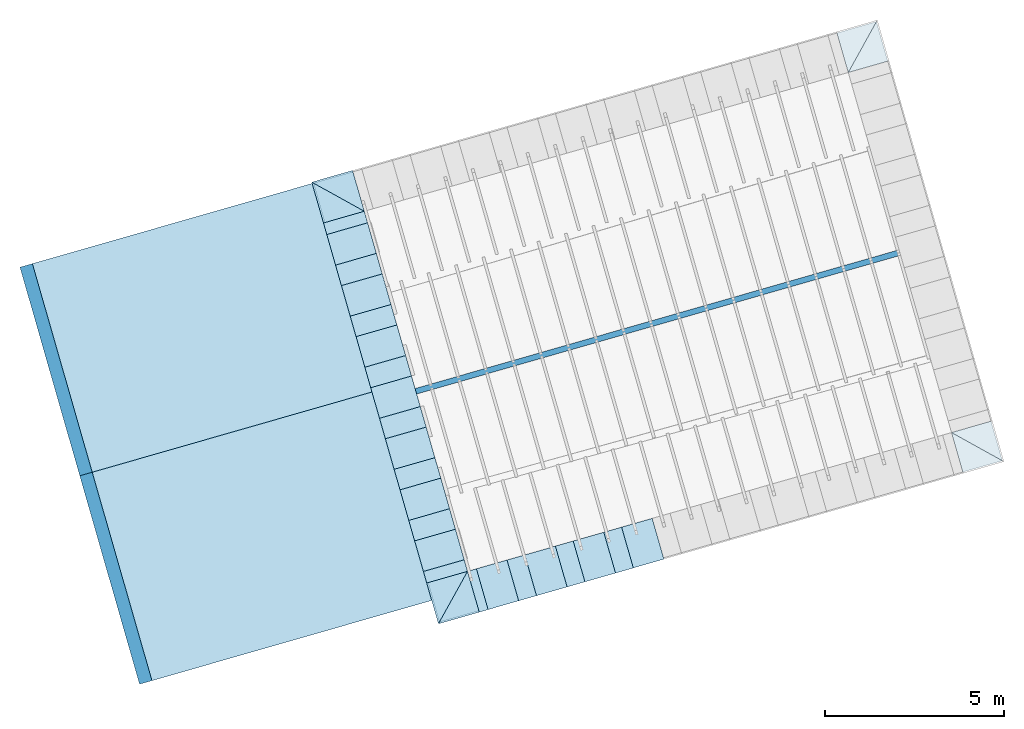
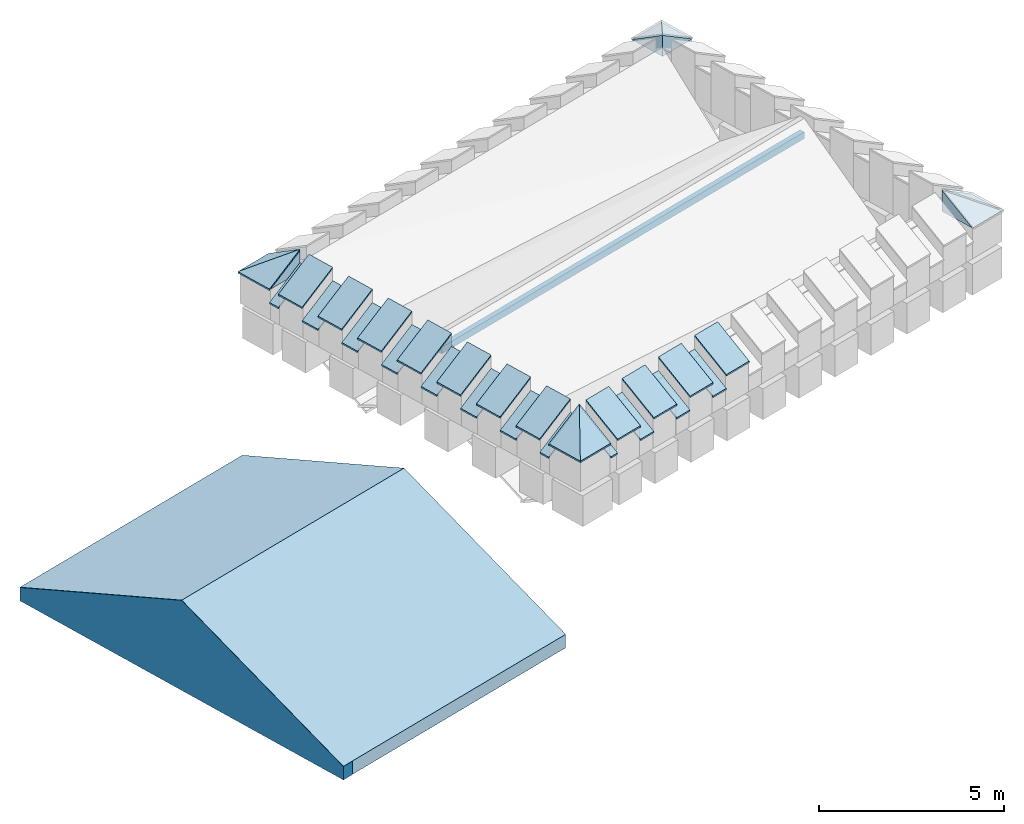
# One storey, part 1 of 10: 27 roofs, 6 slabs, 1 beam.
"""IFC4 building model written with IfcOpenShell, lengths in metres."""

from ifc_helpers import new_model, entity, si_unit, converted_unit, derived_unit, direction, frame, origin_with_axes, place, context, subcontext, project, spatial, polygons, source, transform, mapped, material, type_object, element, save


model = new_model("IFC4")

# Units and contexts
model_context = context("Model", 3, precision=1e-05, world=origin_with_axes(), true_north=direction((0.0, 1.0)))
body_context = subcontext(model_context, "Body", "Model", "MODEL_VIEW")
ifc_project = project(units=[si_unit("LENGTHUNIT", "METRE"), si_unit("AREAUNIT", "SQUARE_METRE"), si_unit("VOLUMEUNIT", "CUBIC_METRE"), converted_unit("PLANEANGLEUNIT", "DEGREE", entity("IfcPlaneAngleMeasure", 0.0174532925199433), si_unit("PLANEANGLEUNIT", "RADIAN"), dimensions=[0, 0, 0, 0, 0, 0, 0]), converted_unit("TIMEUNIT", "Year", entity("IfcTimeMeasure", 31557600.0), si_unit("TIMEUNIT", "SECOND"), dimensions=[0, 0, 1, 0, 0, 0, 0]), si_unit("MASSUNIT", "GRAM", prefix="KILO"), si_unit("THERMODYNAMICTEMPERATUREUNIT", "DEGREE_CELSIUS"), si_unit("LUMINOUSINTENSITYUNIT", "LUMEN"), si_unit("ENERGYUNIT", "JOULE", prefix="MEGA"), derived_unit("THERMALCONDUCTANCEUNIT", [(si_unit("POWERUNIT", "WATT"), 1), (si_unit("LENGTHUNIT", "METRE"), -1), (si_unit("THERMODYNAMICTEMPERATUREUNIT", "KELVIN"), -1)]), derived_unit("SPECIFICHEATCAPACITYUNIT", [(si_unit("ENERGYUNIT", "JOULE"), 1), (si_unit("MASSUNIT", "GRAM", prefix="KILO"), -1), (si_unit("THERMODYNAMICTEMPERATUREUNIT", "KELVIN"), -1)]), derived_unit("MASSDENSITYUNIT", [(si_unit("MASSUNIT", "GRAM", prefix="KILO"), 1), (si_unit("VOLUMEUNIT", "CUBIC_METRE"), -1)])], contexts=[model_context])

# Site, building, storey
site_placement = place(None, frame((0.0, 0.0, 0.0), z_axis=(0.0, 0.0, 1.0), x_axis=(0.9612616959383189, 0.2756373558169991, 0.0)))
site = spatial("IfcSite", under=ifc_project, at=site_placement, CompositionType="ELEMENT")
building_placement = place(site_placement, origin_with_axes())
building = spatial("IfcBuilding", under=site, at=building_placement, CompositionType="ELEMENT")
storey_placement = place(building_placement, frame((0.0, 0.0, 11.0), z_axis=(0.0, 0.0, 1.0), x_axis=(1.0, 0.0, 0.0)))
storey = spatial("IfcBuildingStorey", under=building, at=storey_placement, Name="Dach", CompositionType="ELEMENT", Elevation=11.0)

# Beam
ifc_material_1 = material()
beam_type = type_object("IfcBeamType", Name="160 x 220", PredefinedType="JOIST")
beam_placement = place(storey_placement, frame((15.96285962749732, 12.91602382317144, 1.313903544132387), z_axis=(0.0, 0.0, 1.0), x_axis=(0.0, -1.0, 0.0)))
element("IfcBeam", 1, at=beam_placement, inside=storey, type_object=beam_type, material=ifc_material_1, Name="007", PredefinedType="JOIST", context=body_context, shape_type="Tessellation", body=[
    polygons([(0.08000000000000007, 0.3999999994771404, 0.0), (0.0799999999999983, 14.48857175722328, 0.0), (-0.08000000000000007, 14.48857175722327, 0.0), (-0.08000000000000007, 0.3999999994475179, 0.0), (0.08000000000000007, 0.3999999994771404, -0.2200000000000006), (0.0799999999999983, 14.48857175722328, -0.2200000000000006), (-0.08000000000000007, 14.48857175722327, -0.2200000000000006), (-0.08000000000000007, 0.3999999994475179, -0.2200000000000006)], [[[1, 2, 3, 4]], [[5, 6, 2, 1]], [[6, 7, 3, 2]], [[4, 3, 7, 8]], [[5, 1, 4, 8]], [[8, 7, 6, 5]]], closed=True),
])

# Slabs
ifc_material_2 = material()
slab_type = type_object("IfcSlabType", PredefinedType="FLOOR")
shared_shape = source(origin_with_axes(), body_context, "Body", "Tessellation", [
    polygons([(0.0, -1.149999999999999, 0.0), (0.0, 0.0, 0.0), (1.149999999999999, 0.0, 0.0), (1.150000000000034, -1.149999999999963, 0.0), (0.0, -3.130335102241588e-09, 0.6966400395159482)], [[[1, 2, 3, 4]], [[2, 1, 5]], [[2, 5, 3]], [[5, 4, 3]], [[4, 5, 1]]], closed=True),
])
for number, where, z_axis, x_axis, name in (
    (2, (16.36285962748818, 7.675401456100683, 1.213699411030737), (0.0, 0.0, 1.0), (-4.255298335920088e-10, -1.0, 0.0), "005"),
    (3, (16.3628596269989, 18.15664613147145, 1.213699411030737), (0.0, 0.0, 1.0), (-1.0, 0.0, 0.0), "005"),
    (4, (30.451431388353, 18.15664616645135, 1.213699411030737), (0.0, 0.0, 1.0), (0.0, 1.0, 0.0), "005"),
    (5, (30.45143138835293, 7.675401490534705, 1.213699411030737), (0.0, 0.0, 1.0), (1.0, 0.0, 0.0), "005"),
):
    element("IfcSlab", number, at=place(storey_placement, frame(where, z_axis=z_axis, x_axis=x_axis)), inside=storey, type_object=slab_type, material=ifc_material_2, Name=name, PredefinedType="FLOOR", context=body_context, shape_type="MappedRepresentation", body=[
        mapped(shared_shape, transform((0.0, 0.0, 0.0))),
    ])
slab_1_placement = place(storey_placement, frame((6.670322114749297, 19.30664616645139, -4.86755235235605), z_axis=(0.0, 0.0, 1.0), x_axis=(1.0, 0.0, 0.0)))
element("IfcSlab", 6, at=slab_1_placement, inside=storey, type_object=slab_type, material=ifc_material_2, Name="RD-047", PredefinedType="FLOOR", context=body_context, shape_type="Tessellation", body=[
    polygons([(0.0, -12.13858450669667, -0.4404482433187447), (0.0, -12.13858451131117, 0.001366124695845627), (0.0, -6.070933313513601, 2.527085545902523), (0.0, 0.0, 0.0), (0.0, 0.0, -0.4404482433187447), (0.3609999999999998, -12.13858450669667, -0.4404482433187447), (0.3609999999999998, -12.13858451131117, 0.001366124695845627), (0.3609999999999998, -6.070933313513601, 2.527085545902523), (0.3609999999999998, 0.0, 0.0), (0.3609999999999998, 0.0, -0.4404482433187447)], [[[1, 2, 3, 4, 5]], [[2, 1, 6, 7]], [[3, 2, 7, 8]], [[4, 3, 8, 9]], [[5, 4, 9, 10]], [[1, 5, 10, 6]], [[7, 6, 10, 9, 8]]], closed=True),
])
slab_2_placement = place(storey_placement, frame((6.670322740816097, 19.30663586663675, -4.859551756681256), z_axis=(0.0, 0.0, 1.0), x_axis=(1.0, 0.0, 0.0)))
element("IfcSlab", 7, at=slab_2_placement, inside=storey, type_object=slab_type, material=ifc_material_2, Name="RD-047", PredefinedType="FLOOR", context=body_context, shape_type="Tessellation", body=[
    polygons([(0.0, -12.13858450669667, -0.4404482433187447), (0.0, 0.0, -0.4404482433187447), (8.6398728578916, 0.0, -0.4404482433187447), (8.6398728578916, -12.13858450669667, -0.4404482433187447), (0.0, -12.13858451131117, 0.001366124695845627), (0.0, -6.070933313513601, 2.527085545902523), (0.0, 0.0, 0.0), (8.6398728578916, 0.0, 0.0), (8.6398728578916, -12.13858451131117, 0.001366124695845627), (8.6398728578916, -6.070933313513601, 2.527085545902523)], [[[1, 2, 3, 4]], [[1, 5, 6, 7, 2]], [[2, 7, 8, 3]], [[9, 4, 3, 8, 10]], [[5, 1, 4, 9]], [[6, 5, 9, 10]], [[7, 6, 10, 8]]], closed=True),
])

# Roofs
ifc_material_3 = material(Name="schwarz")
roof_type = type_object("IfcRoofType", Name="schwarz 43", PredefinedType="NOTDEFINED")
roof_1_placement = place(storey_placement, frame((15.21285962724895, 8.901809309526804, 0.7745999999999995), z_axis=(0.0, 0.0, 1.0), x_axis=(0.0, 1.0, 0.0)))
element("IfcRoof", 8, at=roof_1_placement, inside=storey, type_object=roof_type, material=ifc_material_3, Name="Dach-059", PredefinedType="NOTDEFINED", context=body_context, shape_type="Tessellation", body=[
    polygons([(0.0, 0.03772698703645183, 0.02714466037985019), (0.0, -1.149999999999986, 0.7466800857374203), (0.5963999999999974, -1.149999999999993, 0.7466800857374256), (0.5963999999999992, 0.03772698703645183, 0.02714466037985019), (-3.895195277436869e-10, 0.03772698691104104, -0.0228553396741038), (-3.895177513868475e-10, -1.150000000333099, 0.6966800858092945), (0.5963999997654543, -1.150000000333099, 0.6966800858092945), (0.5963999997654525, 0.03772698691104104, -0.0228553396741038)], [[[1, 2, 3, 4]], [[2, 1, 5, 6]], [[3, 2, 6, 7]], [[4, 3, 7, 8]], [[1, 4, 8, 5]], [[6, 5, 8, 7]]], closed=True),
])
roof_2_placement = place(storey_placement, frame((15.21275511774135, 10.38821510795581, 0.7745999999999995), z_axis=(0.0, 0.0, 1.0), x_axis=(0.0, 1.0, 0.0)))
element("IfcRoof", 9, at=roof_2_placement, inside=storey, type_object=roof_type, material=ifc_material_3, Name="Dach-059", PredefinedType="NOTDEFINED", context=body_context, shape_type="Tessellation", body=[
    polygons([(0.0, 0.03772698703645005, 0.02714466037985197), (0.0, -1.149999999999983, 0.7466800857374203), (0.5963999999999974, -1.149999999999993, 0.7466800857374256), (0.5963999999999992, 0.03772698703645005, 0.02714466037985197), (-3.895195277436869e-10, 0.03772698691104281, -0.0228553396741038), (-3.895177513868475e-10, -1.150000000333099, 0.6966800858092945), (0.5963999997654543, -1.150000000333099, 0.6966800858092945), (0.5963999997654525, 0.03772698691104281, -0.0228553396741038)], [[[1, 2, 3, 4]], [[2, 1, 5, 6]], [[3, 2, 6, 7]], [[4, 3, 7, 8]], [[1, 4, 8, 5]], [[6, 5, 8, 7]]], closed=True),
])
roof_3_placement = place(storey_placement, frame((15.21265060823376, 11.87462090638481, 0.7745999999999995), z_axis=(0.0, 0.0, 1.0), x_axis=(0.0, 1.0, 0.0)))
element("IfcRoof", 10, at=roof_3_placement, inside=storey, type_object=roof_type, material=ifc_material_3, Name="Dach-059", PredefinedType="NOTDEFINED", context=body_context, shape_type="Tessellation", body=[
    polygons([(0.0, 0.03772698703645005, 0.02714466037985197), (0.0, -1.149999999999983, 0.7466800857374203), (0.5963999999999974, -1.14999999999999, 0.7466800857374238), (0.5963999999999992, 0.03772698703645005, 0.02714466037985197), (-3.895195277436869e-10, 0.03772698691104637, -0.02285533967410558), (-3.895177513868475e-10, -1.150000000333096, 0.6966800858092927), (0.5963999997654543, -1.150000000333096, 0.6966800858092927), (0.5963999997654525, 0.03772698691104637, -0.02285533967410558)], [[[1, 2, 3, 4]], [[2, 1, 5, 6]], [[3, 2, 6, 7]], [[4, 3, 7, 8]], [[1, 4, 8, 5]], [[6, 5, 8, 7]]], closed=True),
])
roof_4_placement = place(storey_placement, frame((15.21254609872616, 13.36102670481381, 0.7745999999999995), z_axis=(0.0, 0.0, 1.0), x_axis=(0.0, 1.0, 0.0)))
element("IfcRoof", 11, at=roof_4_placement, inside=storey, type_object=roof_type, material=ifc_material_3, Name="Dach-059", PredefinedType="NOTDEFINED", context=body_context, shape_type="Tessellation", body=[
    polygons([(0.0, 0.03772698703645183, 0.02714466037985197), (0.0, -1.149999999999986, 0.7466800857374221), (0.5963999999999974, -1.149999999999993, 0.7466800857374256), (0.5963999999999992, 0.03772698703645183, 0.02714466037985197), (-3.895195277436869e-10, 0.03772698691104104, -0.02285533967410203), (-3.895177513868475e-10, -1.150000000333096, 0.6966800858092945), (0.5963999997654543, -1.150000000333096, 0.6966800858092945), (0.5963999997654525, 0.03772698691104104, -0.02285533967410203)], [[[1, 2, 3, 4]], [[2, 1, 5, 6]], [[3, 2, 6, 7]], [[4, 3, 7, 8]], [[1, 4, 8, 5]], [[6, 5, 8, 7]]], closed=True),
])
roof_5_placement = place(storey_placement, frame((15.21233707971097, 16.33383830167182, 0.7745999999999995), z_axis=(0.0, 0.0, 1.0), x_axis=(0.0, 1.0, 0.0)))
element("IfcRoof", 12, at=roof_5_placement, inside=storey, type_object=roof_type, material=ifc_material_3, Name="Dach-059", PredefinedType="NOTDEFINED", context=body_context, shape_type="Tessellation", body=[
    polygons([(0.0, 0.03772698703645005, 0.02714466037985197), (0.0, -1.149999999999983, 0.7466800857374203), (0.5963999999999956, -1.149999999999993, 0.7466800857374256), (0.5963999999999956, 0.03772698703645005, 0.02714466037985197), (-3.895230804573657e-10, 0.03772698691103926, -0.02285533967410203), (-3.895230804573657e-10, -1.150000000333099, 0.6966800858092945), (0.596399999765449, -1.150000000333099, 0.6966800858092945), (0.596399999765449, 0.03772698691103926, -0.02285533967410203)], [[[1, 2, 3, 4]], [[2, 1, 5, 6]], [[3, 2, 6, 7]], [[4, 3, 7, 8]], [[1, 4, 8, 5]], [[6, 5, 8, 7]]], closed=True),
])
roof_6_placement = place(storey_placement, frame((15.21244158921856, 14.84743250324281, 0.7745999999999995), z_axis=(0.0, 0.0, 1.0), x_axis=(0.0, 1.0, 0.0)))
element("IfcRoof", 13, at=roof_6_placement, inside=storey, type_object=roof_type, material=ifc_material_3, Name="Dach-059", PredefinedType="NOTDEFINED", context=body_context, shape_type="Tessellation", body=[
    polygons([(0.0, 0.03772698703645005, 0.02714466037985197), (0.0, -1.149999999999983, 0.7466800857374185), (0.5963999999999974, -1.149999999999993, 0.7466800857374256), (0.5963999999999992, 0.03772698703645005, 0.02714466037985197), (-3.895195277436869e-10, 0.03772698691104281, -0.0228553396741038), (-3.895177513868475e-10, -1.150000000333099, 0.6966800858092945), (0.5963999997654543, -1.150000000333099, 0.6966800858092945), (0.5963999997654525, 0.03772698691104281, -0.0228553396741038)], [[[1, 2, 3, 4]], [[2, 1, 5, 6]], [[3, 2, 6, 7]], [[4, 3, 7, 8]], [[1, 4, 8, 5]], [[6, 5, 8, 7]]], closed=True),
])
roof_7_placement = place(storey_placement, frame((15.21285963683124, 17.82024085030134, 0.7745999999999995), z_axis=(0.0, 0.0, 1.0), x_axis=(-1.889577760016998e-08, 0.9999999999999999, 0.0)))
element("IfcRoof", 14, at=roof_7_placement, inside=storey, type_object=roof_type, material=ifc_material_3, Name="Dach-058", PredefinedType="NOTDEFINED", context=body_context, shape_type="Tessellation", body=[
    polygons([(0.0, 0.03772698688033849, 0.02714466032907481), (-4.652100926705316e-10, -1.149999993345981, 0.7466800926498482), (0.3364052594399674, -1.149999996524302, 0.7466800945753018), (0.3364054915123695, 0.03772698688034204, 0.02714466032907303), (0.0, 0.03772698706561428, -0.02285534011996937), (-8.373497450975265e-10, -1.149999993671232, 0.6966800925100873), (0.3364052639599855, -1.149999996857451, 0.6966800944403246), (0.3364054958593066, 0.03772698706561428, -0.02285534011996937)], [[[1, 2, 3, 4]], [[2, 1, 5, 6]], [[3, 2, 6, 7]], [[4, 3, 7, 8]], [[1, 4, 8, 5]], [[6, 5, 8, 7]]], closed=True),
])
roof_8_placement = place(storey_placement, frame((15.21233707971098, 17.82024086315237, 1.213699999999999), z_axis=(0.0, 0.0, 1.0), x_axis=(1.867045459603471e-10, -1.0, 0.0)))
element("IfcRoof", 15, at=roof_8_placement, inside=storey, type_object=roof_type, material=ifc_material_3, Name="Dach-060", PredefinedType="NOTDEFINED", context=body_context, shape_type="Tessellation", body=[
    polygons([(0.890002561695237, 1.150000000000009, 0.7466800857374345), (0.0, 1.149999999999991, 0.7466800857374238), (0.0, -0.03772698703640565, 0.02714466037988217), (0.8900025616952512, -0.03772698703640565, 0.02714466037988217), (0.8900025620847671, 1.150000000333115, 0.6966800858093016), (3.51640494500316e-10, 1.150000000333115, 0.6966800858093016), (3.51640494500316e-10, -0.03772698691102505, -0.02285533967409137), (0.8900025620847671, -0.03772698691102505, -0.02285533967409137)], [[[1, 2, 3, 4]], [[2, 1, 5, 6]], [[3, 2, 6, 7]], [[4, 3, 7, 8]], [[1, 4, 8, 5]], [[6, 5, 8, 7]]], closed=True),
])
roof_9_placement = place(storey_placement, frame((15.21285963724604, 7.67540146666147, 0.7745999999999995), z_axis=(0.0, 0.0, 1.0), x_axis=(-1.889577760017003e-08, 0.9999999999999999, 0.0)))
element("IfcRoof", 16, at=roof_9_placement, inside=storey, type_object=roof_type, material=ifc_material_3, Name="Dach-058", PredefinedType="NOTDEFINED", context=body_context, shape_type="Tessellation", body=[
    polygons([(0.0, 0.03772698688034382, 0.02714466032907303), (-4.652154217410498e-10, -1.149999993345984, 0.74668009264985), (0.336405259439962, -1.149999996524302, 0.7466800945753036), (0.3364054915123624, 0.03772698688034204, 0.02714466032907481), (0.0, 0.03772698706561428, -0.02285534011996759), (-8.373559623464644e-10, -1.149999993671235, 0.6966800925100891), (0.3364052639599766, -1.149999996857451, 0.6966800944403282), (0.3364054958592995, 0.03772698706561428, -0.02285534011996759)], [[[1, 2, 3, 4]], [[2, 1, 5, 6]], [[3, 2, 6, 7]], [[4, 3, 7, 8]], [[1, 4, 8, 5]], [[6, 5, 8, 7]]], closed=True),
])
roof_10_placement = place(storey_placement, frame((15.21285962724752, 8.901809309312103, 1.213699999999999), z_axis=(0.0, 0.0, 1.0), x_axis=(1.867205131668775e-10, -1.0, 0.0)))
element("IfcRoof", 17, at=roof_10_placement, inside=storey, type_object=roof_type, material=ifc_material_3, Name="Dach-060", PredefinedType="NOTDEFINED", context=body_context, shape_type="Tessellation", body=[
    polygons([(0.8900025616952529, 1.149999999999993, 0.7466800857374238), (0.0, 1.14999999999999, 0.7466800857374221), (0.0, -0.03772698703640742, 0.02714466037987862), (0.8900025616952529, -0.03772698703640387, 0.02714466037988039), (0.8900025620847707, 1.150000000333099, 0.6966800858092927), (3.516440472139948e-10, 1.150000000333099, 0.6966800858092927), (3.516440472139948e-10, -0.03772698691103926, -0.02285533967410203), (0.8900025620847707, -0.03772698691103926, -0.02285533967410203)], [[[1, 2, 3, 4]], [[2, 1, 5, 6]], [[3, 2, 6, 7]], [[4, 3, 7, 8]], [[1, 4, 8, 5]], [[6, 5, 8, 7]]], closed=True),
])
roof_11_placement = place(storey_placement, frame((15.21285962699505, 11.87461983911674, 1.213699999999999), z_axis=(0.0, 0.0, 1.0), x_axis=(1.867045459603471e-10, -1.0, 0.0)))
element("IfcRoof", 18, at=roof_11_placement, inside=storey, type_object=roof_type, material=ifc_material_3, Name="Dach-060", PredefinedType="NOTDEFINED", context=body_context, shape_type="Tessellation", body=[
    polygons([(0.8900025616952352, 1.150000000000006, 0.7466800857374309), (0.0, 1.149999999999991, 0.7466800857374238), (0.0, -0.03772698703640742, 0.02714466037987862), (0.8900025616952529, -0.03772698703640742, 0.02714466037987862), (0.8900025620847689, 1.150000000333112, 0.6966800858093016), (3.516422708571554e-10, 1.150000000333112, 0.6966800858093016), (3.516422708571554e-10, -0.03772698691102683, -0.02285533967409492), (0.8900025620847689, -0.03772698691102683, -0.02285533967409492)], [[[1, 2, 3, 4]], [[2, 1, 5, 6]], [[3, 2, 6, 7]], [[4, 3, 7, 8]], [[1, 4, 8, 5]], [[6, 5, 8, 7]]], closed=True),
])
roof_12_placement = place(storey_placement, frame((15.21285962712129, 10.38821457421442, 1.213699999999999), z_axis=(0.0, 0.0, 1.0), x_axis=(1.867205131668775e-10, -1.0, 0.0)))
element("IfcRoof", 19, at=roof_12_placement, inside=storey, type_object=roof_type, material=ifc_material_3, Name="Dach-060", PredefinedType="NOTDEFINED", context=body_context, shape_type="Tessellation", body=[
    polygons([(0.8900025616952529, 1.149999999999991, 0.7466800857374238), (0.0, 1.149999999999991, 0.7466800857374238), (0.0, -0.03772698703640565, 0.02714466037988039), (0.8900025616952529, -0.03772698703640565, 0.02714466037988039), (0.8900025620847707, 1.150000000333097, 0.6966800858092927), (3.516440472139948e-10, 1.150000000333097, 0.6966800858092927), (3.516440472139948e-10, -0.03772698691104281, -0.0228553396741038), (0.8900025620847707, -0.03772698691104281, -0.0228553396741038)], [[[1, 2, 3, 4]], [[2, 1, 5, 6]], [[3, 2, 6, 7]], [[4, 3, 7, 8]], [[1, 4, 8, 5]], [[6, 5, 8, 7]]], closed=True),
])
roof_13_placement = place(storey_placement, frame((15.21285962686882, 13.36102510401905, 1.213699999999999), z_axis=(0.0, 0.0, 1.0), x_axis=(1.867045459603471e-10, -1.0, 0.0)))
element("IfcRoof", 20, at=roof_13_placement, inside=storey, type_object=roof_type, material=ifc_material_3, Name="Dach-060", PredefinedType="NOTDEFINED", context=body_context, shape_type="Tessellation", body=[
    polygons([(0.8900025616952352, 1.150000000000007, 0.7466800857374309), (0.0, 1.149999999999993, 0.7466800857374238), (0.0, -0.03772698703640742, 0.02714466037987862), (0.8900025616952529, -0.03772698703640742, 0.02714466037987862), (0.8900025620847689, 1.15000000033311, 0.6966800858093016), (3.516422708571554e-10, 1.15000000033311, 0.6966800858093016), (3.516422708571554e-10, -0.03772698691103038, -0.02285533967409492), (0.8900025620847689, -0.03772698691103038, -0.02285533967409492)], [[[1, 2, 3, 4]], [[2, 1, 5, 6]], [[3, 2, 6, 7]], [[4, 3, 7, 8]], [[1, 4, 8, 5]], [[6, 5, 8, 7]]], closed=True),
])
roof_14_placement = place(storey_placement, frame((15.21285962674258, 14.84743036892137, 1.213699999999999), z_axis=(0.0, 0.0, 1.0), x_axis=(1.867045459603471e-10, -1.0, 0.0)))
element("IfcRoof", 21, at=roof_14_placement, inside=storey, type_object=roof_type, material=ifc_material_3, Name="Dach-060", PredefinedType="NOTDEFINED", context=body_context, shape_type="Tessellation", body=[
    polygons([(0.8900025616952352, 1.150000000000006, 0.7466800857374327), (0.0, 1.149999999999991, 0.7466800857374238), (0.0, -0.03772698703640742, 0.02714466037988039), (0.8900025616952529, -0.03772698703640742, 0.02714466037988039), (0.8900025620847689, 1.150000000333112, 0.6966800858093034), (3.516422708571554e-10, 1.150000000333112, 0.6966800858093034), (3.516422708571554e-10, -0.03772698691102683, -0.02285533967409314), (0.8900025620847689, -0.03772698691102683, -0.02285533967409314)], [[[1, 2, 3, 4]], [[2, 1, 5, 6]], [[3, 2, 6, 7]], [[4, 3, 7, 8]], [[1, 4, 8, 5]], [[6, 5, 8, 7]]], closed=True),
])
roof_15_placement = place(storey_placement, frame((15.21285962661635, 16.33383563382368, 1.213699999999999), z_axis=(0.0, 0.0, 1.0), x_axis=(1.867045459603471e-10, -1.0, 0.0)))
element("IfcRoof", 22, at=roof_15_placement, inside=storey, type_object=roof_type, material=ifc_material_3, Name="Dach-060", PredefinedType="NOTDEFINED", context=body_context, shape_type="Tessellation", body=[
    polygons([(0.8900025616952352, 1.150000000000007, 0.7466800857374327), (0.0, 1.149999999999993, 0.7466800857374256), (0.0, -0.03772698703640742, 0.02714466037987862), (0.8900025616952529, -0.03772698703640742, 0.02714466037987862), (0.8900025620847689, 1.15000000033311, 0.6966800858093016), (3.516440472139948e-10, 1.15000000033311, 0.6966800858093016), (3.516440472139948e-10, -0.03772698691103038, -0.02285533967409492), (0.8900025620847689, -0.03772698691103038, -0.02285533967409492)], [[[1, 2, 3, 4]], [[2, 1, 5, 6]], [[3, 2, 6, 7]], [[4, 3, 7, 8]], [[1, 4, 8, 5]], [[6, 5, 8, 7]]], closed=True),
])
roof_16_placement = place(storey_placement, frame((16.62182045909374, 6.525401459231022, 1.213699999999999), z_axis=(0.0, 0.0, 1.0), x_axis=(1.0, 0.0, 0.0)))
element("IfcRoof", 23, at=roof_16_placement, inside=storey, type_object=roof_type, material=ifc_material_3, Name="Dach-057", PredefinedType="NOTDEFINED", context=body_context, shape_type="Tessellation", body=[
    polygons([(0.8900025616952547, -0.03772698703644384, 0.0271446603798573), (0.8900025616952547, 1.15, 0.7466800857374345), (0.0, 1.15, 0.7466800857374345), (0.0, -0.03772698703644384, 0.0271446603798573), (0.8900025620847707, -0.03772698691103216, -0.0228553396740967), (0.8900025620847707, 1.150000000333107, 0.6966800858093052), (3.516440472139948e-10, 1.150000000333107, 0.6966800858093052), (3.516440472139948e-10, -0.03772698691103216, -0.0228553396740967)], [[[1, 2, 3, 4]], [[2, 1, 5, 6]], [[3, 2, 6, 7]], [[4, 3, 7, 8]], [[1, 4, 8, 5]], [[6, 5, 8, 7]]], closed=True),
])
roof_17_placement = place(storey_placement, frame((18.03078129542637, 6.525401462361394, 1.213699999999999), z_axis=(0.0, 0.0, 1.0), x_axis=(1.0, 0.0, 0.0)))
element("IfcRoof", 24, at=roof_17_placement, inside=storey, type_object=roof_type, material=ifc_material_3, Name="Dach-057", PredefinedType="NOTDEFINED", context=body_context, shape_type="Tessellation", body=[
    polygons([(0.8900025616952547, -0.03772698703644206, 0.0271446603798573), (0.8900025616952547, 1.15, 0.7466800857374345), (0.0, 1.15, 0.7466800857374345), (0.0, -0.03772698703644206, 0.0271446603798573), (0.8900025620847707, -0.03772698691103216, -0.0228553396740967), (0.8900025620847707, 1.150000000333107, 0.6966800858093052), (3.516440472139948e-10, 1.150000000333107, 0.6966800858093052), (3.516440472139948e-10, -0.03772698691103216, -0.0228553396740967)], [[[1, 2, 3, 4]], [[2, 1, 5, 6]], [[3, 2, 6, 7]], [[4, 3, 7, 8]], [[1, 4, 8, 5]], [[6, 5, 8, 7]]], closed=True),
])
roof_18_placement = place(storey_placement, frame((19.43974213175898, 6.525401465491766, 1.213699999999999), z_axis=(0.0, 0.0, 1.0), x_axis=(1.0, 0.0, 0.0)))
element("IfcRoof", 25, at=roof_18_placement, inside=storey, type_object=roof_type, material=ifc_material_3, Name="Dach-057", PredefinedType="NOTDEFINED", context=body_context, shape_type="Tessellation", body=[
    polygons([(0.8900025616952547, -0.03772698703644295, 0.0271446603798573), (0.8900025616952547, 1.150000000000001, 0.7466800857374345), (0.0, 1.15, 0.7466800857374327), (0.0, -0.03772698703644295, 0.0271446603798573), (0.8900025620847707, -0.03772698691103038, -0.0228553396740967), (0.8900025620847707, 1.150000000333108, 0.6966800858093052), (3.516440472139948e-10, 1.150000000333108, 0.6966800858093052), (3.516440472139948e-10, -0.03772698691103038, -0.0228553396740967)], [[[1, 2, 3, 4]], [[2, 1, 5, 6]], [[3, 2, 6, 7]], [[4, 3, 7, 8]], [[1, 4, 8, 5]], [[6, 5, 8, 7]]], closed=True),
])
roof_19_placement = place(storey_placement, frame((20.84870296809161, 6.525401468622138, 1.213699999999999), z_axis=(0.0, 0.0, 1.0), x_axis=(1.0, 0.0, 0.0)))
element("IfcRoof", 26, at=roof_19_placement, inside=storey, type_object=roof_type, material=ifc_material_3, Name="Dach-057", PredefinedType="NOTDEFINED", context=body_context, shape_type="Tessellation", body=[
    polygons([(0.8900025616952547, -0.03772698703644295, 0.0271446603798573), (0.8900025616952547, 1.150000000000001, 0.7466800857374345), (0.0, 1.150000000000001, 0.7466800857374345), (0.0, -0.03772698703644295, 0.0271446603798573), (0.8900025620847707, -0.03772698691103127, -0.0228553396740967), (0.8900025620847707, 1.150000000333108, 0.6966800858093052), (3.516440472139948e-10, 1.150000000333108, 0.6966800858093052), (3.516440472139948e-10, -0.03772698691103127, -0.0228553396740967)], [[[1, 2, 3, 4]], [[2, 1, 5, 6]], [[3, 2, 6, 7]], [[4, 3, 7, 8]], [[1, 4, 8, 5]], [[6, 5, 8, 7]]], closed=True),
])
roof_20_placement = place(storey_placement, frame((15.21285962748818, 7.675401456590007, 1.213699411030737), z_axis=(0.0, 0.0, 1.0), x_axis=(-4.254853474381183e-10, -1.0, 0.0)))
element("IfcRoof", 27, at=roof_20_placement, inside=storey, type_object=roof_type, material=ifc_material_3, Name="Dach-056", PredefinedType="NOTDEFINED", context=body_context, shape_type="Tessellation", body=[
    polygons([(1.187727569304739, -0.03772756920204401, 0.02714484985627585), (0.0, 1.149999996869667, 0.7466392679559579), (0.0, -0.03772756970743352, 0.02714484955012075), (1.187727569692952, -0.03772756928763421, -0.02285437876551022), (0.0, 1.149999997201515, 0.6966400395870469), (0.0, -0.03772757008420058, -0.02285437924805045)], [[[1, 2, 3]], [[2, 1, 4, 5]], [[3, 2, 5, 6]], [[1, 3, 6, 4]], [[5, 4, 6]]], closed=True),
])
roof_21_placement = place(storey_placement, frame((15.21285962699887, 6.525401456590009, 1.213699411030737), z_axis=(0.0, 0.0, 1.0), x_axis=(1.0, -4.254992493612092e-10, 0.0)))
element("IfcRoof", 28, at=roof_21_placement, inside=storey, type_object=roof_type, material=ifc_material_3, Name="Dach-055", PredefinedType="NOTDEFINED", context=body_context, shape_type="Tessellation", body=[
    polygons([(1.149999999980858, -0.03772756930474053, 0.02714484981973797), (1.149999996747814, 1.149999999878155, 0.7466392678456124), (-0.03772756920204579, -0.03772756930473964, 0.02714484981973975), (1.150000000439869, -0.03772756953676026, -0.0228543788542126), (1.149999996714579, 1.150000000273935, 0.6966400395519674), (-0.03772756922519349, -0.03772756953676026, -0.0228543788542126)], [[[1, 2, 3]], [[2, 1, 4, 5]], [[3, 2, 5, 6]], [[1, 3, 6, 4]], [[5, 4, 6]]], closed=True),
])
roof_22_placement = place(storey_placement, frame((15.21285962699886, 19.3066461314714, 1.21369941103074), z_axis=(0.0, 0.0, 1.0), x_axis=(0.0, -1.0, 0.0)))
element("IfcRoof", 29, at=roof_22_placement, inside=storey, type_object=roof_type, material=ifc_material_3, Name="Dach-054", PredefinedType="NOTDEFINED", context=body_context, shape_type="Tessellation", body=[
    polygons([(1.15000000005703, -0.03772756924567666, 0.02714484985551557), (1.149999996824, 1.149999999954323, 0.7466392678917533), (-0.03772756914296949, -0.03772756924566778, 0.02714484985552268), (1.150000000516041, -0.03772756946059275, -0.02285437880807173), (1.149999996790751, 1.150000000350103, 0.69664003959811), (-0.03772756914901976, -0.03772756946059275, -0.02285437880807173)], [[[1, 2, 3]], [[2, 1, 4, 5]], [[3, 2, 5, 6]], [[1, 3, 6, 4]], [[5, 4, 6]]], closed=True),
])
roof_23_placement = place(storey_placement, frame((16.36285962699886, 19.30664613147145, 1.213699411030737), z_axis=(0.0, 0.0, 1.0), x_axis=(-1.0, 0.0, 0.0)))
element("IfcRoof", 30, at=roof_23_placement, inside=storey, type_object=roof_type, material=ifc_material_3, Name="Dach-053", PredefinedType="NOTDEFINED", context=body_context, shape_type="Tessellation", body=[
    polygons([(1.187727569245649, -0.03772756914297304, 0.02714484989205701), (0.0, 1.149999996869646, 0.7466392679559455), (0.0, -0.03772756914296593, 0.02714484989206234), (1.187727569633834, -0.03772756928762888, -0.02285437876550667), (0.0, 1.149999997201498, 0.6966400395870362), (0.0, -0.03772756928762888, -0.02285437876550667)], [[[1, 2, 3]], [[2, 1, 4, 5]], [[3, 2, 5, 6]], [[1, 3, 6, 4]], [[5, 4, 6]]], closed=True),
])
roof_24_placement = place(storey_placement, frame((20.3297446934503, 6.54338846264864, 0.7745999999999995), z_axis=(0.0, 0.0, 1.0), x_axis=(1.0, 0.0, 0.0)))
element("IfcRoof", 31, at=roof_24_placement, inside=storey, type_object=roof_type, material=ifc_material_3, Name="Dach-048", PredefinedType="NOTDEFINED", context=body_context, shape_type="Tessellation", body=[
    polygons([(0.5189582746531372, -0.05571398314985654, 0.01624798038468178), (0.51895827465313, 1.132013003886586, 0.7357834057422572), (0.0, 1.132013003886584, 0.7357834057422572), (0.0, -0.05571398314985831, 0.01624798038468001), (0.5189582750426531, -0.05571398302444663, -0.03375201966927222), (0.5189582750426531, 1.132013004219693, 0.6857834058141279), (-1.637339153148787e-10, 1.132013004219693, 0.6857834058141279), (-1.637339153148787e-10, -0.05571398302444663, -0.03375201966927222)], [[[1, 2, 3, 4]], [[2, 1, 5, 6]], [[3, 2, 6, 7]], [[4, 3, 7, 8]], [[1, 4, 8, 5]], [[6, 5, 8, 7]]], closed=True),
])
roof_25_placement = place(storey_placement, frame((17.511823020789, 6.543388455692257, 0.7745999999999995), z_axis=(0.0, 0.0, 1.0), x_axis=(1.0, 0.0, 0.0)))
element("IfcRoof", 32, at=roof_25_placement, inside=storey, type_object=roof_type, material=ifc_material_3, Name="Dach-048", PredefinedType="NOTDEFINED", context=body_context, shape_type="Tessellation", body=[
    polygons([(0.5189582746531372, -0.05571398314985565, 0.01624798038468178), (0.51895827465313, 1.132013003886586, 0.735783405742259), (0.0, 1.132013003886583, 0.7357834057422572), (0.0, -0.05571398314985831, 0.01624798038468001), (0.5189582750426531, -0.05571398302444575, -0.03375201966927222), (0.5189582750426531, 1.132013004219694, 0.6857834058141297), (-1.637339153148787e-10, 1.132013004219694, 0.6857834058141297), (-1.637339153148787e-10, -0.05571398302444575, -0.03375201966927222)], [[[1, 2, 3, 4]], [[2, 1, 5, 6]], [[3, 2, 6, 7]], [[4, 3, 7, 8]], [[1, 4, 8, 5]], [[6, 5, 8, 7]]], closed=True),
])
roof_26_placement = place(storey_placement, frame((16.36285884205106, 6.543388455344433, 0.7745999999999995), z_axis=(0.0, 0.0, 1.0), x_axis=(1.0, 0.0, 0.0)))
element("IfcRoof", 33, at=roof_26_placement, inside=storey, type_object=roof_type, material=ifc_material_3, Name="Dach-048", PredefinedType="NOTDEFINED", context=body_context, shape_type="Tessellation", body=[
    polygons([(0.2589616170426865, -0.05571398314985565, 0.01624798038468356), (0.2589616170426936, 1.132013003886586, 0.735783405742259), (0.0, 1.132013003886587, 0.7357834057422608), (0.0, -0.05571398314985476, 0.01624798038468356), (0.2589616174322096, -0.05571398302444486, -0.03375201966927044), (0.2589616174322096, 1.132013004219695, 0.6857834058141314), (4.1690739749356e-10, 1.132013004219695, 0.6857834058141314), (4.1690739749356e-10, -0.05571398302444486, -0.03375201966927044)], [[[1, 2, 3, 4]], [[2, 1, 5, 6]], [[3, 2, 6, 7]], [[4, 3, 7, 8]], [[1, 4, 8, 5]], [[6, 5, 8, 7]]], closed=True),
])
roof_27_placement = place(storey_placement, frame((18.92078385711965, 6.543388459170449, 0.7745999999999995), z_axis=(0.0, 0.0, 1.0), x_axis=(1.0, 0.0, 0.0)))
element("IfcRoof", 34, at=roof_27_placement, inside=storey, type_object=roof_type, material=ifc_material_3, Name="Dach-048", PredefinedType="NOTDEFINED", context=body_context, shape_type="Tessellation", body=[
    polygons([(0.5189582746531372, -0.05571398314985743, 0.01624798038468178), (0.51895827465313, 1.132013003886587, 0.735783405742259), (0.0, 1.132013003886583, 0.7357834057422572), (0.0, -0.05571398314985831, 0.01624798038468001), (0.5189582750426531, -0.05571398302444486, -0.03375201966927222), (0.5189582750426531, 1.132013004219694, 0.6857834058141297), (-1.637339153148787e-10, 1.132013004219694, 0.6857834058141297), (-1.637339153148787e-10, -0.05571398302444486, -0.03375201966927222)], [[[1, 2, 3, 4]], [[2, 1, 5, 6]], [[3, 2, 6, 7]], [[4, 3, 7, 8]], [[1, 4, 8, 5]], [[6, 5, 8, 7]]], closed=True),
])

save(model, "model.ifc")
